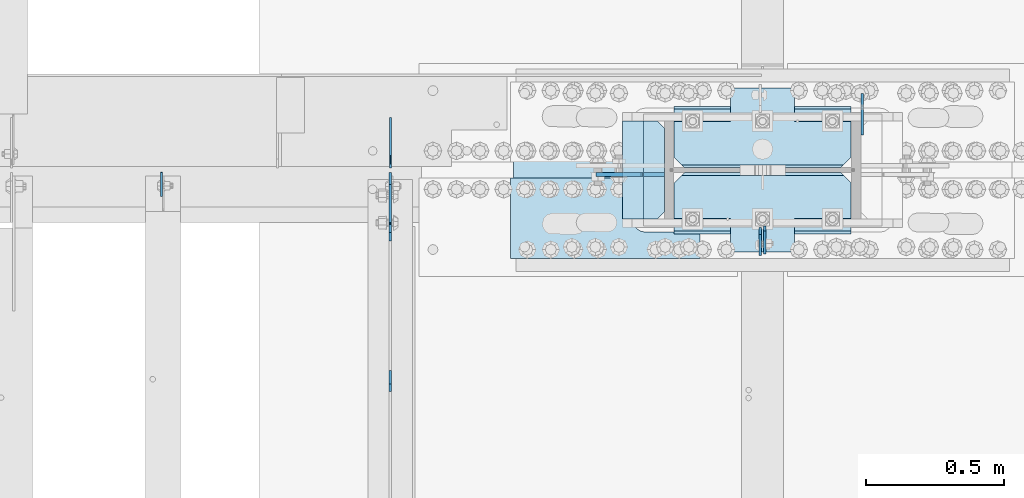
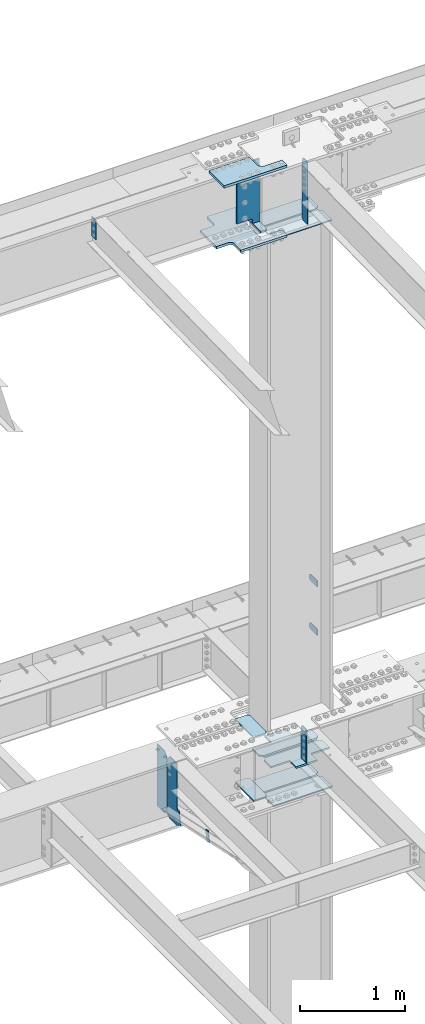
# One storey, part 1616 of 1763: 20 plates, 6 elements without a shape of their own.
"""IFC2X3 building model written with IfcOpenShell, lengths in millimetres."""

import ifcopenshell
import ifcopenshell.guid

model = None  # the IFC model being written
_history = None  # IfcOwnerHistory: only IFC2X3 demands one
_inside = {}  # id of a spatial element -> (the spatial element, [elements in it])
_under = {}  # id of a project, library or spatial element -> (it, [spatial elements below it])
_declared = {}  # id of a project -> (the project, [libraries it declares])
_typed = {}  # id of a type object -> (the type object, [elements of that type])
_made_of = {}  # id of a material, layer set ... -> (it, [elements and type objects made of it])


def new_model(schema):
    """Start an empty IFC model of exactly this schema.

    Asked for "IFC4X3", IfcOpenShell would pick the latest addendum, in which some entities
    have other attributes; the version numbers below select the first issue.
    IFC2X3 requires an IfcOwnerHistory on every rooted entity: one is made here for all.
    """
    global model, _history
    if schema == "IFC4X3":
        model = ifcopenshell.file(schema_version=(4, 3, 0, 0))
    else:
        model = ifcopenshell.file(schema=schema)
    _inside.clear()
    _under.clear()
    _declared.clear()
    _typed.clear()
    _made_of.clear()
    _history = None
    if model.schema == "IFC2X3":
        org = make("IfcOrganization", Name="unknown")
        user = make(
            "IfcPersonAndOrganization",
            ThePerson=make("IfcPerson", FamilyName="unknown"),
            TheOrganization=org,
        )
        app = make(
            "IfcApplication",
            ApplicationDeveloper=org,
            Version="unknown",
            ApplicationFullName="unknown",
            ApplicationIdentifier="unknown",
        )
        _history = make(
            "IfcOwnerHistory",
            OwningUser=user,
            OwningApplication=app,
            ChangeAction="ADDED",
            CreationDate=0,
        )
    return model


def make(cls, **values):
    """One entity of the class cls with the attributes given. An attribute that is None is left unset."""
    return model.create_entity(
        cls, **{name: value for name, value in values.items() if value is not None}
    )


def rooted(cls, **values):
    """An entity with a GlobalId (a new one), such as an element, a storey or a relation."""
    return make(cls, GlobalId=ifcopenshell.guid.new(), OwnerHistory=_history, **values)


def si_unit(unit_type, name, prefix=None):
    """IfcSIUnit, for example si_unit("LENGTHUNIT", "METRE", prefix="MILLI")."""
    return make("IfcSIUnit", UnitType=unit_type, Prefix=prefix, Name=name)


def assignment(units):
    """IfcUnitAssignment: the units of a project."""
    return None if units is None else make("IfcUnitAssignment", Units=units)


def point(xyz):
    """IfcCartesianPoint."""
    return None if xyz is None else make("IfcCartesianPoint", Coordinates=xyz)


def direction(xyz):
    """IfcDirection."""
    return None if xyz is None else make("IfcDirection", DirectionRatios=xyz)


def frame(location, z_axis=None, x_axis=None):
    """IfcAxis2Placement3D, a coordinate frame: its origin and axes. An axis left out is left unset."""
    return make(
        "IfcAxis2Placement3D",
        Location=point(location),
        Axis=direction(z_axis),
        RefDirection=direction(x_axis),
    )


def origin_with_axes():
    """The frame at (0, 0, 0) with the z axis (0, 0, 1) and the x axis (1, 0, 0) written out."""
    return frame((0.0, 0.0, 0.0), z_axis=(0.0, 0.0, 1.0), x_axis=(1.0, 0.0, 0.0))


def place(relative_to, where):
    """IfcLocalPlacement: puts the frame where relative to a parent placement (None: the world)."""
    return make(
        "IfcLocalPlacement", PlacementRelTo=relative_to, RelativePlacement=where
    )


def context(
    kind, dimensions, precision=None, world=None, true_north=None, identifier=None
):
    """IfcGeometricRepresentationContext, for example the 3D "Model" context."""
    return make(
        "IfcGeometricRepresentationContext",
        ContextIdentifier=identifier,
        ContextType=kind,
        CoordinateSpaceDimension=dimensions,
        Precision=precision,
        WorldCoordinateSystem=world,
        TrueNorth=true_north,
    )


def subcontext(parent, identifier, kind, view, scale=None):
    """IfcGeometricRepresentationSubContext, for example "Body" below "Model"."""
    return make(
        "IfcGeometricRepresentationSubContext",
        ContextIdentifier=identifier,
        ContextType=kind,
        ParentContext=parent,
        TargetScale=scale,
        TargetView=view,
    )


def project(units=None, contexts=None):
    """IfcProject with its units and contexts."""
    return rooted(
        "IfcProject",
        Name="project",
        RepresentationContexts=contexts,
        UnitsInContext=assignment(units),
    )


def spatial(cls, under=None, at=None, **own):
    """A site, building, storey or space (cls), placed at a placement, below another one or the project."""
    s = rooted(cls, ObjectPlacement=at, **own)
    if under is not None:
        _under.setdefault(under.id(), (under, []))[1].append(s)
    return s


def faces_of(points, faces, orient=None, outer=None):
    """IfcFace entities. A face is a list of loops; a loop is a list of indices into points, from 0.

    orient and outer hold one flag for each loop. By default every Orientation is true, the
    first loop of a face is its IfcFaceOuterBound and the others are IfcFaceBound.
    """
    made = []
    for i, loops in enumerate(faces):
        bounds = []
        for j, loop in enumerate(loops):
            is_outer = j == 0 if outer is None else outer[i][j]
            bounds.append(
                make(
                    "IfcFaceOuterBound" if is_outer else "IfcFaceBound",
                    Bound=make("IfcPolyLoop", Polygon=[points[k] for k in loop]),
                    Orientation=True if orient is None else orient[i][j],
                )
            )
        made.append(make("IfcFace", Bounds=bounds))
    return made


def faceted_brep(points, faces, orient=None, outer=None, voids=None):
    """IfcFacetedBrep: a solid bounded by flat faces; with voids (closed shells), ...WithVoids."""
    shared = [point(p) for p in points]
    hull = make("IfcClosedShell", CfsFaces=faces_of(shared, faces, orient, outer))
    if voids is None:
        return make("IfcFacetedBrep", Outer=hull)
    return make(
        "IfcFacetedBrepWithVoids",
        Outer=hull,
        Voids=[
            make(cls, CfsFaces=faces_of(shared, fs, o, b)) for cls, fs, o, b in voids
        ],
    )


def shape(context_of_items, identifier, shape_type, items):
    """IfcShapeRepresentation: the items that make up one representation, for example the "Body"."""
    return make(
        "IfcShapeRepresentation",
        ContextOfItems=context_of_items,
        RepresentationIdentifier=identifier,
        RepresentationType=shape_type,
        Items=items,
    )


def material(Name=None, Category=None):
    """IfcMaterial."""
    return make("IfcMaterial", Name=Name, Category=Category)


def made_of(thing, what):
    """Note that an element or type object is made of a material, layer set ...; save() writes the relation."""
    if what is not None:
        _made_of.setdefault(what.id(), (what, []))[1].append(thing)
    return thing


def type_object(cls, material=None, **own):
    """A type object (cls), such as IfcWallType, which elements share."""
    return made_of(rooted(cls, **own), material)


def element(
    cls,
    number,
    at=None,
    inside=None,
    cuts=None,
    type_object=None,
    material=None,
    context=None,
    identifier="Body",
    shape_type=None,
    held_by="IfcProductDefinitionShape",
    body=None,
    shapes=None,
    **own,
):
    """One element of the class cls, such as IfcWall. Its Tag is "e" and its number.

    at: its placement. inside: the storey or other place that contains it. cuts: it is an
    opening in that element (IfcRelVoidsElement). A single representation is given by context,
    identifier, shape_type and body (its items); several are given by shapes. held_by: the class
    of the entity that holds the representations. save() writes the other relations.
    """
    e = rooted(cls, Tag="e%d" % number, ObjectPlacement=at, **own)
    if body is not None:
        shapes = [shape(context, identifier, shape_type, body)]
    if shapes is not None:
        e.Representation = make(held_by, Representations=shapes)
    if inside is not None:
        _inside.setdefault(inside.id(), (inside, []))[1].append(e)
    if cuts is not None:
        rooted(
            "IfcRelVoidsElement", RelatingBuildingElement=cuts, RelatedOpeningElement=e
        )
    if type_object is not None:
        _typed.setdefault(type_object.id(), (type_object, []))[1].append(e)
    return made_of(e, material)


def aggregate(whole, parts):
    """IfcRelAggregates: a whole, such as a stair, and the parts it consists of."""
    return rooted("IfcRelAggregates", RelatingObject=whole, RelatedObjects=parts)


def save(model, path):
    """Write the relations noted so far, then the file.

    IfcRelAggregates (storeys below a building ...), IfcRelContainedInSpatialStructure (elements
    in a storey), IfcRelDefinesByType, IfcRelAssociatesMaterial and IfcRelDeclares: one each for
    every whole, place, type object, material and project.
    """
    for whole, parts in _under.values():
        aggregate(whole, parts)
    for where, things in _inside.values():
        rooted(
            "IfcRelContainedInSpatialStructure",
            RelatedElements=things,
            RelatingStructure=where,
        )
    for kind, things in _typed.values():
        rooted("IfcRelDefinesByType", RelatedObjects=things, RelatingType=kind)
    for what, things in _made_of.values():
        rooted("IfcRelAssociatesMaterial", RelatedObjects=things, RelatingMaterial=what)
    for by, libraries in _declared.values():
        rooted("IfcRelDeclares", RelatingContext=by, RelatedDefinitions=libraries)
    model.write(path)


model = new_model("IFC2X3")

# Units and contexts
model_context = context("Model", 3, precision=1e-05, world=origin_with_axes())
body_context = subcontext(model_context, "Body", "Model", "MODEL_VIEW")
ifc_project = project(units=[si_unit("LENGTHUNIT", "METRE", prefix="MILLI"), si_unit("AREAUNIT", "SQUARE_METRE"), si_unit("VOLUMEUNIT", "CUBIC_METRE"), si_unit("MASSUNIT", "GRAM", prefix="KILO"), si_unit("TIMEUNIT", "SECOND"), si_unit("PLANEANGLEUNIT", "RADIAN"), si_unit("SOLIDANGLEUNIT", "STERADIAN"), si_unit("THERMODYNAMICTEMPERATUREUNIT", "DEGREE_CELSIUS"), si_unit("LUMINOUSINTENSITYUNIT", "LUMEN")], contexts=[model_context])

# Site, building, storey
site_placement = place(None, origin_with_axes())
site = spatial("IfcSite", under=ifc_project, at=site_placement, CompositionType="ELEMENT")
building_placement = place(site_placement, origin_with_axes())
building = spatial("IfcBuilding", under=site, at=building_placement, Name="Undefined", CompositionType="ELEMENT")
storey_placement = place(building_placement, origin_with_axes())
storey = spatial("IfcBuildingStorey", under=building, at=storey_placement, Name="Undefined", CompositionType="ELEMENT", Elevation=0.0)

# Assembly, plates
assembly_1_placement = place(storey_placement, origin_with_axes())
assembly_1 = element("IfcElementAssembly", 1, at=assembly_1_placement, inside=storey, Name="COLUMN", AssemblyPlace="NOTDEFINED", PredefinedType="RIGID_FRAME")
ifc_material_1 = material(Name="STEEL/A36")
plate_type_1 = type_object("IfcPlateType", PredefinedType="NOTDEFINED")
plate_1_placement = place(assembly_1_placement, frame((-61232.4872736984, 52247.8, 6489.69999847412), z_axis=(0.0, 0.0, -1.0), x_axis=(0.0, 1.0, 0.0)))
plate_1 = element("IfcPlate", 2, at=plate_1_placement, type_object=plate_type_1, material=ifc_material_1, Name="PLATE", context=body_context, shape_type="Brep", body=[
    faceted_brep([(0.0, -4.76249999999982, 0.0), (0.0, -4.76250000000073, 76.1999969482422), (0.0, 4.76250000000073, 76.1999969482422), (0.0, 4.76249999999982, 0.0), (114.299995422363, -4.76250000000073, 76.1999969482422), (114.299995422363, 4.76250000000073, 76.1999969482422), (126.073542436527, -4.76250000000073, 74.3352502937696), (126.073542436527, 4.76250000000073, 74.3352502937696), (136.694612637817, -4.76250000000073, 68.923544725345), (136.694612637817, 4.76250000000073, 68.923544725345), (145.123541673587, -4.76250000000073, 60.4946156895749), (145.123541673587, 4.76250000000073, 60.4946156895749), (150.535247242013, -4.76250000000073, 49.8735454882844), (150.535247242013, 4.76250000000073, 49.8735454882844), (152.399993896484, -4.76250000000073, 38.0999984741211), (152.399993896484, 4.76250000000073, 38.0999984741211), (150.535247242013, -4.76250000000073, 26.3264514599578), (150.535247242013, 4.76250000000073, 26.3264514599578), (145.123541673587, -4.76250000000073, 15.7053812586673), (145.123541673587, 4.76250000000073, 15.7053812586673), (136.694612637817, -4.76250000000073, 7.27645222289721), (136.694612637817, 4.76250000000073, 7.27645222289721), (126.073542436527, -4.76250000000073, 1.86474665447258), (126.073542436527, 4.76250000000073, 1.86474665447258), (114.299995422363, -4.76250000000073, 0.0), (114.299995422363, 4.76250000000073, 0.0)], [[[0, 1, 2, 3]], [[1, 4, 5, 2]], [[4, 6, 7, 5]], [[6, 8, 9, 7]], [[8, 10, 11, 9]], [[10, 12, 13, 11]], [[12, 14, 15, 13]], [[14, 16, 17, 15]], [[16, 18, 19, 17]], [[18, 20, 21, 19]], [[20, 22, 23, 21]], [[22, 24, 25, 23]], [[24, 0, 3, 25]], [[5, 7, 9, 11, 13, 15, 17, 19, 21, 23, 25, 3, 2]], [[24, 22, 20, 18, 16, 14, 12, 10, 8, 6, 4, 1, 0]]]),
])
plate_2_placement = place(assembly_1_placement, frame((-61232.4872736984, 52247.8, 5930.89999847412), z_axis=(0.0, 0.0, -1.0), x_axis=(0.0, 1.0, 0.0)))
plate_2 = element("IfcPlate", 3, at=plate_2_placement, type_object=plate_type_1, material=ifc_material_1, Name="PLATE", context=body_context, shape_type="Brep", body=[
    faceted_brep([(0.0, -4.76249999999982, 0.0), (0.0, -4.76250000000073, 76.1999969482422), (0.0, 4.76250000000073, 76.1999969482422), (0.0, 4.76249999999982, 0.0), (114.299995422363, -4.76250000000073, 76.1999969482422), (114.299995422363, 4.76250000000073, 76.1999969482422), (126.073542436527, -4.76250000000073, 74.3352502937696), (126.073542436527, 4.76250000000073, 74.3352502937696), (136.694612637817, -4.76250000000073, 68.923544725345), (136.694612637817, 4.76250000000073, 68.923544725345), (145.123541673587, -4.76250000000073, 60.4946156895749), (145.123541673587, 4.76250000000073, 60.4946156895749), (150.535247242013, -4.76250000000073, 49.8735454882844), (150.535247242013, 4.76250000000073, 49.8735454882844), (152.399993896484, -4.76250000000073, 38.0999984741211), (152.399993896484, 4.76250000000073, 38.0999984741211), (150.535247242013, -4.76250000000073, 26.3264514599578), (150.535247242013, 4.76250000000073, 26.3264514599578), (145.123541673587, -4.76250000000073, 15.7053812586673), (145.123541673587, 4.76250000000073, 15.7053812586673), (136.694612637817, -4.76250000000073, 7.27645222289721), (136.694612637817, 4.76250000000073, 7.27645222289721), (126.073542436527, -4.76250000000073, 1.86474665447258), (126.073542436527, 4.76250000000073, 1.86474665447258), (114.299995422363, -4.76250000000073, 0.0), (114.299995422363, 4.76250000000073, 0.0)], [[[0, 1, 2, 3]], [[1, 4, 5, 2]], [[4, 6, 7, 5]], [[6, 8, 9, 7]], [[8, 10, 11, 9]], [[10, 12, 13, 11]], [[12, 14, 15, 13]], [[14, 16, 17, 15]], [[16, 18, 19, 17]], [[18, 20, 21, 19]], [[20, 22, 23, 21]], [[22, 24, 25, 23]], [[24, 0, 3, 25]], [[5, 7, 9, 11, 13, 15, 17, 19, 21, 23, 25, 3, 2]], [[24, 22, 20, 18, 16, 14, 12, 10, 8, 6, 4, 1, 0]]]),
])

# Assembly, plate
assembly_2_placement = place(storey_placement, origin_with_axes())
assembly_2 = element("IfcElementAssembly", 4, at=assembly_2_placement, inside=storey, Name="ANGLE BRACE", AssemblyPlace="NOTDEFINED", PredefinedType="RIGID_FRAME")
plate_type_2 = type_object("IfcPlateType", PredefinedType="NOTDEFINED")
plate_3_placement = place(assembly_2_placement, frame((-62948.5747736983, 51342.4281032895, 4746.91590772782), z_axis=(0.0, -0.208168683014592, -0.978092940068566), x_axis=(0.0, 0.978092940068566, -0.208168683014588)))
plate_3 = element("IfcPlate", 5, at=plate_3_placement, type_object=plate_type_2, material=ifc_material_1, Name="PLATE", context=body_context, shape_type="Brep", body=[
    faceted_brep([(0.0, -4.76249999999982, 0.0), (2.11002770811319e-09, -4.76249999999709, 127.040328979458), (2.11002770811319e-09, 4.76249999999709, 127.040328979458), (0.0, 4.76249999999982, 0.0), (50.7119293213109, -4.76249999999709, 126.999992370584), (50.7119293213109, 4.76249999999709, 126.999992370584), (50.7119293211581, -4.76249999999709, 1.63709046319127e-11), (50.7119293211581, 4.76249999999709, 1.63709046319127e-11)], [[[0, 1, 2, 3]], [[1, 4, 5, 2]], [[4, 6, 7, 5]], [[6, 0, 3, 7]], [[5, 7, 3, 2]], [[6, 4, 1, 0]]]),
])
aggregate(assembly_2, [plate_3])

# Plate
plate_type_3 = type_object("IfcPlateType", PredefinedType="NOTDEFINED")
plate_4_placement = place(assembly_1_placement, frame((-61586.5002737632, 51917.5999999994, 11718.1532534164), z_axis=(0.0, -1.0, 0.0), x_axis=(0.0, 0.0, -1.0)))
plate_4 = element("IfcPlate", 6, at=plate_4_placement, type_object=plate_type_3, material=ifc_material_1, Name="PLATE", context=body_context, shape_type="Brep", body=[
    faceted_brep([(0.0, -3.96899999999732, 19.0499992370605), (-1.18234311230481e-11, -3.96900000000096, 101.599998474121), (-1.18234311230481e-11, 3.96900000000096, 101.599998474121), (0.0, 3.96899999999732, 19.0499992370605), (719.137512207031, -3.96899999999732, 101.599998474121), (719.137512207031, 3.96899999999732, 101.599998474121), (719.137512207031, -3.96899999999732, 19.0499992370605), (719.137512207031, 3.96899999999732, 19.0499992370605), (700.087512969971, -3.96899999999732, 0.0), (700.087512969971, 3.96899999999732, 0.0), (19.0499992370605, -3.96899999999732, 0.0), (19.0499992370605, 3.96899999999732, 0.0)], [[[0, 1, 2, 3]], [[1, 4, 5, 2]], [[4, 6, 7, 5]], [[6, 8, 9, 7]], [[8, 10, 11, 9]], [[10, 0, 3, 11]], [[5, 7, 9, 11, 3, 2]], [[10, 8, 6, 4, 1, 0]]]),
])

ifc_material_2 = material(Name="STEEL/A572-GR.50")
plate_type_4 = type_object("IfcPlateType", PredefinedType="NOTDEFINED")
plate_5_placement = place(assembly_1_placement, frame((-61603.1685236983, 51911.25, 5165.725), z_axis=(0.0, -1.0, 0.0), x_axis=(0.0, 0.0, -1.0)))
plate_5 = element("IfcPlate", 7, at=plate_5_placement, type_object=plate_type_4, material=ifc_material_2, Name="PLATE", context=body_context, shape_type="Brep", body=[
    faceted_brep([(25.3999996185303, -4.76250000000073, 0.0), (0.0, -4.76250000000073, 25.3999996185303), (0.0, 4.76250000000073, 25.3999996185303), (25.3999996185303, 4.76250000000073, 0.0), (1.45519152283669e-11, -4.76250000000448, 101.60001373291), (390.524993896484, -4.76249999999709, 101.599998474121), (390.524993896484, 4.76249999999709, 101.599998474121), (0.0, 4.76250000000243, 101.60001373291), (390.524993896484, -4.76249999999709, 0.0), (390.524993896484, 4.76249999999709, 0.0)], [[[0, 1, 2, 3]], [[4, 5, 6, 7]], [[5, 8, 9, 6]], [[9, 8, 0, 3]], [[7, 6, 9, 3, 2]], [[4, 7, 2, 1]], [[8, 5, 4, 1, 0]]]),
])

# Assembly, plate
assembly_3_placement = place(storey_placement, origin_with_axes())
assembly_3 = element("IfcElementAssembly", 8, at=assembly_3_placement, inside=storey, Name="BEAM", AssemblyPlace="NOTDEFINED", PredefinedType="RIGID_FRAME")
plate_type_5 = type_object("IfcPlateType", PredefinedType="NOTDEFINED")
plate_6_placement = place(assembly_3_placement, frame((-62946.987273746, 52128.7375, 4448.175), z_axis=(0.0, 0.0, 1.0), x_axis=(0.0, 1.0, 0.0)))
plate_6 = element("IfcPlate", 9, at=plate_6_placement, type_object=plate_type_5, material=ifc_material_1, Name="PLATE", context=body_context, shape_type="Brep", body=[
    faceted_brep([(0.0, -3.17500000000291, 44.4500000000007), (0.0, -3.17500000000291, 673.099987030029), (0.0, 3.17500000000291, 673.099987030029), (0.0, 3.17500000000291, 44.4500000000007), (44.4500007629395, -3.17500000000291, 717.549987792969), (44.4500007629395, 3.17500000000291, 717.549987792969), (182.5625, -3.17500000000291, 717.549987792969), (182.5625, 3.17500000000291, 717.549987792969), (182.5625, -3.17500000000291, 0.0), (182.5625, 3.17500000000291, 0.0), (44.4500007629395, -3.17500000000291, 0.0), (44.4500007629395, 3.17500000000291, 0.0)], [[[0, 1, 2, 3]], [[1, 4, 5, 2]], [[4, 6, 7, 5]], [[6, 8, 9, 7]], [[8, 10, 11, 9]], [[10, 0, 3, 11]], [[5, 7, 9, 11, 3, 2]], [[10, 8, 6, 4, 1, 0]]]),
])

# Plate
ifc_material_3 = material(Name="STEEL/A572-50")
plate_type_6 = type_object("IfcPlateType", PredefinedType="NOTDEFINED")
plate_7_placement = place(assembly_1_placement, frame((-62104.0247736984, 52298.6, 4427.5375), z_axis=(1.0, 0.0, 0.0), x_axis=(0.0, -1.0, 0.0)))
plate_7 = element("IfcPlate", 10, at=plate_7_placement, type_object=plate_type_6, material=ifc_material_3, Name="PLATE", context=body_context, shape_type="Brep", body=[
    faceted_brep([(-7.27595761418343e-12, -7.9375, 0.0), (0.0, -7.9375, 126.999994277954), (0.0, 7.9375, 126.999994277954), (-7.27595761418343e-12, 7.9375, 0.0), (25.3999996185303, -7.9375, 152.399993896484), (25.3999996185303, 7.9375, 152.399993896484), (330.200006484985, -7.9375, 152.399993896484), (330.200006484985, 7.9375, 152.399993896484), (355.600006103516, -7.9375, 126.999994277954), (355.600006103516, 7.9375, 126.999994277954), (355.600006103516, -7.9375, 0.0), (355.600006103516, 7.9375, 0.0)], [[[0, 1, 2, 3]], [[1, 4, 5, 2]], [[4, 6, 7, 5]], [[6, 8, 9, 7]], [[8, 10, 11, 9]], [[10, 0, 3, 11]], [[5, 7, 9, 11, 3, 2]], [[10, 8, 6, 4, 1, 0]]]),
])

plate_8_placement = place(assembly_1_placement, frame((-62104.0247736984, 52298.6, 5157.7875), z_axis=(1.0, 0.0, 0.0), x_axis=(0.0, -1.0, 0.0)))
plate_8 = element("IfcPlate", 11, at=plate_8_placement, type_object=plate_type_6, material=ifc_material_3, Name="PLATE", context=body_context, shape_type="Brep", body=[
    faceted_brep([(-7.27595761418343e-12, -7.9375, 0.0), (0.0, -7.9375, 126.999994277954), (0.0, 7.9375, 126.999994277954), (-7.27595761418343e-12, 7.9375, 0.0), (25.3999996185303, -7.9375, 152.399993896484), (25.3999996185303, 7.9375, 152.399993896484), (330.200006484985, -7.9375, 152.399993896484), (330.200006484985, 7.9375, 152.399993896484), (355.600006103516, -7.9375, 126.999994277954), (355.600006103516, 7.9375, 126.999994277954), (355.600006103516, -7.9375, 0.0), (355.600006103516, 7.9375, 0.0)], [[[0, 1, 2, 3]], [[1, 4, 5, 2]], [[4, 6, 7, 5]], [[6, 8, 9, 7]], [[8, 10, 11, 9]], [[10, 0, 3, 11]], [[5, 7, 9, 11, 3, 2]], [[10, 8, 6, 4, 1, 0]]]),
])

plate_type_7 = type_object("IfcPlateType", PredefinedType="NOTDEFINED")
plate_9_placement = place(assembly_1_placement, frame((-61916.6997736983, 51889.025, 4335.4625), z_axis=(1.0, 0.0, 0.0), x_axis=(0.0, 1.0, 0.0)))
plate_9 = element("IfcPlate", 12, at=plate_9_placement, type_object=plate_type_7, material=ifc_material_3, Name="HORIZONTAL SHEAR PLAT", context=body_context, shape_type="Brep", body=[
    faceted_brep([(-7.27595761418343e-12, -7.9375, 0.0), (0.0, -7.9375, 644.524963378906), (0.0, 7.9375, 644.524963378906), (-7.27595761418343e-12, 7.9375, 0.0), (184.150001525879, -7.9375, 644.524963378906), (184.150001525879, 7.9375, 644.524963378906), (222.25, -7.9375, 606.424964904785), (222.25, 7.9375, 606.424964904785), (222.25, -7.9375, 38.0999984741211), (222.25, 7.9375, 38.0999984741211), (184.150001525879, -7.9375, 0.0), (184.150001525879, 7.9375, 0.0)], [[[0, 1, 2, 3]], [[1, 4, 5, 2]], [[4, 6, 7, 5]], [[6, 8, 9, 7]], [[8, 10, 11, 9]], [[10, 0, 3, 11]], [[5, 7, 9, 11, 3, 2]], [[10, 8, 6, 4, 1, 0]]]),
])

plate_10_placement = place(assembly_1_placement, frame((-61916.6997736983, 52352.575, 4335.4625), z_axis=(1.0, 0.0, 0.0), x_axis=(0.0, -1.0, 0.0)))
plate_10 = element("IfcPlate", 13, at=plate_10_placement, type_object=plate_type_7, material=ifc_material_3, Name="HORIZONTAL SHEAR PLAT", context=body_context, shape_type="Brep", body=[
    faceted_brep([(-7.27595761418343e-12, -7.9375, 0.0), (0.0, -7.9375, 644.524963378906), (0.0, 7.9375, 644.524963378906), (-7.27595761418343e-12, 7.9375, 0.0), (184.150001525879, -7.9375, 644.524963378906), (184.150001525879, 7.9375, 644.524963378906), (222.25, -7.9375, 606.424964904785), (222.25, 7.9375, 606.424964904785), (222.25, -7.9375, 38.0999984741211), (222.25, 7.9375, 38.0999984741211), (184.150001525879, -7.9375, 0.0), (184.150001525879, 7.9375, 0.0)], [[[0, 1, 2, 3]], [[1, 4, 5, 2]], [[4, 6, 7, 5]], [[6, 8, 9, 7]], [[8, 10, 11, 9]], [[10, 0, 3, 11]], [[5, 7, 9, 11, 3, 2]], [[10, 8, 6, 4, 1, 0]]]),
])

plate_type_8 = type_object("IfcPlateType", PredefinedType="NOTDEFINED")
plate_11_placement = place(assembly_1_placement, frame((-61272.1747736983, 51898.55, 10887.0749917654), z_axis=(-1.0, 0.0, 0.0), x_axis=(0.0, 1.0, 0.0)))
plate_11 = element("IfcPlate", 14, at=plate_11_placement, type_object=plate_type_8, material=ifc_material_3, Name="PLATE", context=body_context, shape_type="Brep", body=[
    faceted_brep([(0.0, -6.34999999999491, 1.45519152283669e-11), (0.0, -6.35000000000036, 644.525024414062), (0.0, 6.35000000000036, 644.525024414062), (0.0, 6.34999999999491, -2.91038304567337e-11), (174.625007629395, -6.35000000000036, 644.525024414062), (174.625007629395, 6.35000000000036, 644.525024414062), (212.725006103516, -6.35000000000036, 606.425025939941), (212.725006103516, 6.35000000000036, 606.425025939941), (212.725006103516, -6.35000000000036, 38.0999984741211), (212.725006103516, 6.35000000000036, 38.0999984741211), (174.625007629395, -6.35000000000036, 0.0), (174.625007629395, 6.35000000000036, 0.0)], [[[0, 1, 2, 3]], [[1, 4, 5, 2]], [[4, 6, 7, 5]], [[6, 8, 9, 7]], [[8, 10, 11, 9]], [[10, 0, 3, 11]], [[5, 7, 9, 11, 3, 2]], [[10, 8, 6, 4, 1, 0]]]),
])

plate_12_placement = place(assembly_1_placement, frame((-61272.1747736983, 52130.325, 10887.0749917654), z_axis=(-1.0, 0.0, 0.0), x_axis=(0.0, 1.0, 0.0)))
plate_12 = element("IfcPlate", 15, at=plate_12_placement, type_object=plate_type_8, material=ifc_material_3, Name="PLATE", context=body_context, shape_type="Brep", body=[
    faceted_brep([(0.0, -6.34999999999854, 38.0999984741211), (0.0, -6.35000000000036, 606.425025939941), (0.0, 6.35000000000036, 606.425025939941), (0.0, 6.34999999999854, 38.0999984741211), (38.0999984741211, -6.35000000000036, 644.525024414062), (38.0999984741211, 6.35000000000036, 644.525024414062), (212.725006103516, -6.35000000000036, 644.525024414062), (212.725006103516, 6.35000000000036, 644.525024414062), (212.725006103516, -6.35000000000036, 0.0), (212.725006103516, 6.35000000000036, 0.0), (38.0999984741211, -6.34999999999854, 0.0), (38.0999984741211, 6.34999999999854, 0.0)], [[[0, 1, 2, 3]], [[1, 4, 5, 2]], [[4, 6, 7, 5]], [[6, 8, 9, 7]], [[8, 10, 11, 9]], [[10, 0, 3, 11]], [[5, 7, 9, 11, 3, 2]], [[10, 8, 6, 4, 1, 0]]]),
])

plate_type_9 = type_object("IfcPlateType", PredefinedType="NOTDEFINED")
plate_13_placement = place(assembly_1_placement, frame((-61272.1747736983, 51822.35, 4749.8), z_axis=(-1.0, 0.0, 0.0), x_axis=(0.0, 1.0, 0.0)))
plate_13 = element("IfcPlate", 16, at=plate_13_placement, type_object=plate_type_9, material=ifc_material_3, Name="PLATE", context=body_context, shape_type="Brep", body=[
    faceted_brep([(288.924987792969, -7.65116965339985e-07, 606.425025939941), (279.399988558085, -9.52499999999964, 615.950025174825), (279.399988558085, -9.52499999999964, 28.5749992392375), (288.924987792969, -7.65116965339985e-07, 38.0999984741211), (250.824989318848, -9.52499999999964, 644.525024414062), (250.824989318848, 9.52499999999964, 644.525024414062), (122.237487792991, 9.52499999999964, 644.525024414062), (122.237487792991, -9.52499999999964, 644.525015258769), (122.237487792983, 9.52499999999964, 438.14999999998), (122.237487792983, -9.52499999999964, 438.14999999998), (0.0, 9.52499999999964, 438.149991923026), (0.0, -9.52499999999964, 438.149991923026), (0.0, 9.52499999999964, 206.375007181632), (0.0, -9.52499999999964, 206.375007181632), (250.824989318848, 9.52499999999964, 0.0), (250.824989318848, -9.52499999999964, 0.0), (122.237487792998, -9.52499999999964, 0.0), (122.237487792998, 9.52499999999964, 0.0), (122.237487793005, -9.52499999999964, 206.375015258775), (122.237487793005, 9.52499999999964, 206.375015258775), (288.924987792969, 9.52499999999964, 606.425025939941), (288.924987792969, 9.52499999999964, 38.0999984741211)], [[[0, 1, 2, 3]], [[4, 5, 6, 7]], [[7, 6, 8, 9]], [[9, 8, 10, 11]], [[11, 10, 12, 13]], [[14, 15, 16, 17]], [[18, 19, 17, 16]], [[13, 12, 19, 18]], [[10, 8, 6, 5, 20, 21, 14, 17, 19, 12]], [[21, 20, 0, 3]], [[15, 14, 21, 3, 2]], [[4, 7, 9, 11, 13, 18, 16, 15, 2, 1]], [[20, 5, 4, 1, 0]]]),
])

plate_14_placement = place(assembly_1_placement, frame((-61272.1747736983, 52130.325, 4749.8), z_axis=(-1.0, 0.0, 0.0), x_axis=(0.0, 1.0, 0.0)))
plate_14 = element("IfcPlate", 17, at=plate_14_placement, type_object=plate_type_9, material=ifc_material_3, Name="PLATE", context=body_context, shape_type="Brep", body=[
    faceted_brep([(9.52499923488358, -9.52499999999964, 615.950025174825), (0.0, -7.65116965339985e-07, 606.425025939941), (0.0, 0.0, 38.0999984741211), (9.52499923488358, -9.52499999999964, 28.5749992392375), (288.924987792961, -9.52499999999964, 438.14999999998), (288.924987792969, 9.52499999999964, 438.14999999998), (166.687499999833, 9.52499999999964, 438.149991923055), (166.687499999833, -9.52499999999964, 438.149991923055), (288.924987792983, -9.52499999999964, 206.375015258775), (288.924987792969, 9.52499999999964, 206.375015258775), (38.0999984741211, -9.52500000000146, 0.0), (38.0999984741211, 9.52500000000146, 0.0), (166.6875, 9.52499999999964, 0.0), (166.6875, -9.52499999999964, 0.0), (166.687503076391, 9.52499999999964, 206.375007181618), (166.687503076391, -9.52499999999964, 206.375007181618), (0.0, 9.52500000000146, 38.0999984741211), (0.0, 9.52499999999964, 606.425025939941), (38.0999984741211, 9.52499999999964, 644.525024414062), (166.687503076224, 9.52499999999964, 644.525024414062), (166.687503076224, -9.52499999999964, 644.525024414062), (38.0999984741211, -9.52499999999964, 644.525024414062)], [[[0, 1, 2, 3]], [[4, 5, 6, 7]], [[5, 4, 8, 9]], [[10, 11, 12, 13]], [[13, 12, 14, 15]], [[8, 15, 14, 9]], [[12, 11, 16, 17, 18, 19, 6, 5, 9, 14]], [[20, 7, 6, 19]], [[18, 21, 20, 19]], [[10, 13, 15, 8, 4, 7, 20, 21, 0, 3]], [[16, 11, 10, 3, 2]], [[17, 16, 2, 1]], [[21, 18, 17, 1, 0]]]),
])

# Assembly, plate
assembly_4_placement = place(storey_placement, origin_with_axes())
assembly_4 = element("IfcElementAssembly", 18, at=assembly_4_placement, inside=storey, Name="PLATE", AssemblyPlace="NOTDEFINED", PredefinedType="RIGID_FRAME")
plate_type_10 = type_object("IfcPlateType", PredefinedType="NOTDEFINED")
plate_15_placement = place(assembly_4_placement, frame((-61821.4497736984, 52441.4750002128, 10955.3374917654), z_axis=(0.0, -1.0, 0.0), x_axis=(-1.0, 0.0, 0.0)))
plate_15 = element("IfcPlate", 19, at=plate_15_placement, type_object=plate_type_10, material=ifc_material_3, Name="PLATE", context=body_context, shape_type="Brep", body=[
    faceted_brep([(0.0, -14.2875000000058, 0.0), (0.0, -14.2875000000004, 95.25), (0.0, 14.2875000000004, 95.25), (0.0, 14.2875000000058, 0.0), (209.550006866455, -14.2875000000004, 95.25), (209.550006866455, 14.2875000000004, 95.25), (220.342425159237, -14.2875000000004, 96.9593511310522), (220.342425159237, 14.2875000000004, 96.9593511310522), (230.078406354325, -14.2875000000004, 101.920081325748), (230.078406354325, 14.2875000000004, 101.920081325748), (237.804924777767, -14.2875000000004, 109.646599749191), (237.804924777767, 14.2875000000004, 109.646599749191), (242.765654972463, -14.2875000000004, 119.382580944279), (242.765654972463, 14.2875000000004, 119.382580944279), (244.475006103516, -14.2875000000004, 130.174999237061), (244.475006103516, 14.2875000000004, 130.174999237061), (244.475006103516, -14.2875000000004, 511.174976348877), (244.475006103516, 14.2875000000004, 511.174976348877), (242.765654972463, -14.2875000000004, 521.967394641659), (242.765654972463, 14.2875000000004, 521.967394641659), (237.804924777767, -14.2875000000004, 531.703375836747), (237.804924777767, 14.2875000000004, 531.703375836747), (230.078406354325, -14.2875000000004, 539.429894260189), (230.078406354325, 14.2875000000004, 539.429894260189), (220.342425159237, -14.2875000000004, 544.390624454885), (220.342425159237, 14.2875000000004, 544.390624454885), (209.550006866455, -14.2875000000004, 546.099975585938), (209.550006866455, 14.2875000000004, 546.099975585938), (0.0, -14.2875000000004, 546.099975585938), (0.0, 14.2875000000004, 546.099975585938), (0.0, -14.2875000000004, 641.349975585938), (0.0, 14.2875000000004, 641.349975585938), (508.0, -14.2875000000004, 641.349975585938), (508.0, 14.2875000000004, 641.349975585938), (508.0, -14.2875000000004, 511.174999237061), (508.0, 14.2875000000004, 511.174999237061), (509.709351131052, -14.2875000000004, 500.382580944279), (509.709351131052, 14.2875000000004, 500.382580944279), (514.670081325748, -14.2875000000004, 490.646599749191), (514.670081325748, 14.2875000000004, 490.646599749191), (522.396599749191, -14.2875000000004, 482.920081325748), (522.396599749191, 14.2875000000004, 482.920081325748), (532.132580944279, -14.2875000000004, 477.959351131052), (532.132580944279, 14.2875000000004, 477.959351131052), (542.924999237061, -14.2875000000004, 476.25), (542.924999237061, 14.2875000000004, 476.25), (679.450012207031, -14.2875000000004, 476.25), (679.450012207031, 14.2875000000004, 476.25), (679.450012207031, -14.2875000000004, 165.100006103516), (679.450012207031, 14.2875000000004, 165.100006103516), (542.924999237061, -14.2875000000004, 165.100006103516), (542.924999237061, 14.2875000000004, 165.100006103516), (532.132580944279, -14.2875000000004, 163.390654972463), (532.132580944279, 14.2875000000004, 163.390654972463), (522.396599749191, -14.2875000000004, 158.429924777767), (522.396599749191, 14.2875000000004, 158.429924777767), (514.670081325748, -14.2875000000004, 150.703406354325), (514.670081325748, 14.2875000000004, 150.703406354325), (509.709351131052, -14.2875000000004, 140.967425159237), (509.709351131052, 14.2875000000004, 140.967425159237), (508.0, -14.2875000000004, 130.175006866455), (508.0, 14.2875000000004, 130.175006866455), (508.0, -14.2875000000004, 0.0), (508.0, 14.2875000000004, 0.0)], [[[0, 1, 2, 3]], [[1, 4, 5, 2]], [[4, 6, 7, 5]], [[6, 8, 9, 7]], [[8, 10, 11, 9]], [[10, 12, 13, 11]], [[12, 14, 15, 13]], [[14, 16, 17, 15]], [[16, 18, 19, 17]], [[18, 20, 21, 19]], [[20, 22, 23, 21]], [[22, 24, 25, 23]], [[24, 26, 27, 25]], [[26, 28, 29, 27]], [[28, 30, 31, 29]], [[30, 32, 33, 31]], [[32, 34, 35, 33]], [[34, 36, 37, 35]], [[36, 38, 39, 37]], [[38, 40, 41, 39]], [[40, 42, 43, 41]], [[42, 44, 45, 43]], [[44, 46, 47, 45]], [[46, 48, 49, 47]], [[48, 50, 51, 49]], [[50, 52, 53, 51]], [[52, 54, 55, 53]], [[54, 56, 57, 55]], [[56, 58, 59, 57]], [[58, 60, 61, 59]], [[60, 62, 63, 61]], [[62, 0, 3, 63]], [[5, 7, 9, 11, 13, 15, 17, 19, 21, 23, 25, 27, 29, 31, 33, 35, 37, 39, 41, 43, 45, 47, 49, 51, 53, 55, 57, 59, 61, 63, 3, 2]], [[62, 60, 58, 56, 54, 52, 50, 48, 46, 44, 42, 40, 38, 36, 34, 32, 30, 28, 26, 24, 22, 20, 18, 16, 14, 12, 10, 8, 6, 4, 1, 0]]]),
])
aggregate(assembly_4, [plate_15])

assembly_5_placement = place(storey_placement, origin_with_axes())
assembly_5 = element("IfcElementAssembly", 20, at=assembly_5_placement, inside=storey, Name="TOP PLATE", AssemblyPlace="NOTDEFINED", PredefinedType="RIGID_FRAME")
plate_type_11 = type_object("IfcPlateType", PredefinedType="NOTDEFINED")
plate_16_placement = place(assembly_5_placement, frame((-62065.9247736984, 52092.2250002128, 11761.7874917654), z_axis=(0.0, -1.0, 0.0), x_axis=(-1.0, 0.0, 0.0)))
plate_16 = element("IfcPlate", 21, at=plate_16_placement, type_object=plate_type_11, material=ifc_material_3, Name="TOP PLATE", context=body_context, shape_type="Brep", body=[
    faceted_brep([(0.0, -14.2875000000058, 0.0), (0.0, -14.2875000000004, 152.400001525879), (0.0, 14.2875000000004, 152.400001525879), (0.0, 14.2875000000058, 0.0), (-3.38355483795021, -14.2875000000004, 169.410284201171), (-3.38355483795021, 14.2875000000004, 169.410284201171), (-13.0191037997211, -14.2875000000004, 183.830902303795), (-13.0191037997211, 14.2875000000004, 183.830902303795), (-27.4397219023449, -14.2875000000004, 193.466451265565), (-27.4397219023449, 14.2875000000004, 193.466451265565), (-44.4500007629395, -14.2875000000004, 196.850006103516), (-44.4500007629395, 14.2875000000004, 196.850006103516), (-244.475006103516, -14.2875000000004, 196.850006103516), (-244.475006103516, 14.2875000000004, 196.850006103516), (-244.475006103516, -14.2875000000004, 292.100006103516), (-244.475006103516, 14.2875000000004, 292.100006103516), (444.5, -14.2875000000004, 292.100006103516), (444.5, 14.2875000000004, 292.100006103516), (444.5, -14.2875000000004, 0.0), (444.5, 14.2875000000004, 0.0)], [[[0, 1, 2, 3]], [[1, 4, 5, 2]], [[4, 6, 7, 5]], [[6, 8, 9, 7]], [[8, 10, 11, 9]], [[10, 12, 13, 11]], [[12, 14, 15, 13]], [[14, 16, 17, 15]], [[16, 18, 19, 17]], [[18, 0, 3, 19]], [[5, 7, 9, 11, 13, 15, 17, 19, 3, 2]], [[18, 16, 14, 12, 10, 8, 6, 4, 1, 0]]]),
])
aggregate(assembly_5, [plate_16])

# Plate
plate_type_12 = type_object("IfcPlateType", PredefinedType="NOTDEFINED")
plate_17_placement = place(assembly_1_placement, frame((-61951.6247736983, 51943.0, 10980.7374917654), z_axis=(-1.0, 0.0, 0.0), x_axis=(0.0, 1.0, 0.0)))
plate_17 = element("IfcPlate", 22, at=plate_17_placement, type_object=plate_type_12, material=ifc_material_3, Name="BRIDGE PLATE", context=body_context, shape_type="Brep", body=[
    faceted_brep([(0.0, -11.1124999999993, 25.3999996185303), (0.0, -11.1124999999993, 76.1999969482422), (0.0, 11.1124999999993, 76.1999969482422), (0.0, 11.1124999999993, 25.3999996185303), (355.600006103516, -11.1124999999993, 76.1999969482422), (355.600006103516, 11.1124999999993, 76.1999969482422), (355.600006103516, -11.1124999999993, 25.3999996185303), (355.600006103516, 11.1124999999993, 25.3999996185303), (330.200006484985, -11.1124999999993, 0.0), (330.200006484985, 11.1124999999993, 0.0), (25.3999996185303, -11.1124999999993, 0.0), (25.3999996185303, 11.1124999999993, 0.0)], [[[0, 1, 2, 3]], [[1, 4, 5, 2]], [[4, 6, 7, 5]], [[6, 8, 9, 7]], [[8, 10, 11, 9]], [[10, 0, 3, 11]], [[5, 7, 9, 11, 3, 2]], [[10, 8, 6, 4, 1, 0]]]),
])

plate_type_13 = type_object("IfcPlateType", PredefinedType="NOTDEFINED")
plate_18_placement = place(assembly_1_placement, frame((-62199.2747736984, 52104.9250002128, 11045.8249917654), z_axis=(1.0, 0.0, 0.0), x_axis=(0.0, 0.0, 1.0)))
plate_18 = element("IfcPlate", 23, at=plate_18_placement, type_object=plate_type_13, material=ifc_material_3, Name="SHEAR TAB", context=body_context, shape_type="Brep", body=[
    faceted_brep([(-7.27595761418343e-12, -7.9375, 0.0), (0.0, -7.9375, 158.749997138977), (0.0, 7.9375, 158.749997138977), (-7.27595761418343e-12, 7.9375, 0.0), (-0.966729922587547, -7.9375, 163.610076657023), (-0.966729922587547, 7.9375, 163.610076657023), (-3.71974382306507, -7.9375, 167.730253125177), (-3.71974382306507, 7.9375, 167.730253125177), (-7.83992029121873, -7.9375, 170.483267025651), (-7.83992029121873, 7.9375, 170.483267025651), (-12.6999998092651, -7.9375, 171.449996948242), (-12.6999998092651, 7.9375, 171.449996948242), (-53.9749984741211, -7.9375, 171.449996948242), (-53.9749984741211, 7.9375, 171.449996948242), (-53.9749984741211, -7.9375, 247.649993896484), (-53.9749984741211, 7.9375, 247.649993896484), (671.512451171875, -7.9375, 247.649993896484), (671.512451171875, 7.9375, 247.649993896484), (671.512451171875, -7.9375, 171.449996948242), (671.512451171875, 7.9375, 171.449996948242), (638.174975395203, -7.9375, 171.449996948242), (638.174975395203, 7.9375, 171.449996948242), (633.314895877156, -7.9375, 170.483267025651), (633.314895877156, 7.9375, 170.483267025651), (629.194719409003, -7.9375, 167.730253125177), (629.194719409003, 7.9375, 167.730253125177), (626.441705508525, -7.9375, 163.610076657023), (626.441705508525, 7.9375, 163.610076657023), (625.474975585938, -7.9375, 158.749997138977), (625.474975585938, 7.9375, 158.749997138977), (625.474975585938, -7.9375, 0.0), (625.474975585938, 7.9375, 0.0)], [[[0, 1, 2, 3]], [[1, 4, 5, 2]], [[4, 6, 7, 5]], [[6, 8, 9, 7]], [[8, 10, 11, 9]], [[10, 12, 13, 11]], [[12, 14, 15, 13]], [[14, 16, 17, 15]], [[16, 18, 19, 17]], [[18, 20, 21, 19]], [[20, 22, 23, 21]], [[22, 24, 25, 23]], [[24, 26, 27, 25]], [[26, 28, 29, 27]], [[28, 30, 31, 29]], [[30, 0, 3, 31]], [[5, 7, 9, 11, 13, 15, 17, 19, 21, 23, 25, 27, 29, 31, 3, 2]], [[30, 28, 26, 24, 22, 20, 18, 16, 14, 12, 10, 8, 6, 4, 1, 0]]]),
])

aggregate(assembly_1, [plate_1, plate_2, plate_9, plate_10, plate_7, plate_8, plate_11, plate_12, plate_13, plate_14, plate_4, plate_17, plate_18, plate_5])

plate_type_14 = type_object("IfcPlateType", PredefinedType="NOTDEFINED")
plate_19_placement = place(assembly_3_placement, frame((-62948.574773746, 52112.8625, 4448.175), z_axis=(0.0, 0.0, 1.0), x_axis=(0.0, -1.0, 0.0)))
plate_19 = element("IfcPlate", 24, at=plate_19_placement, type_object=plate_type_14, material=ifc_material_1, Name="PLATE", context=body_context, shape_type="Brep", body=[
    faceted_brep([(-8.03411239758134e-08, -4.76249999999709, 44.4500007629395), (-1.21945049613714e-06, -4.76249999999709, 674.687450408936), (-1.21945049613714e-06, 4.76249999999709, 674.687450408936), (-8.03411239758134e-08, 4.76249999999709, 44.4500007629395), (44.4499994631478, -4.76249999999709, 719.137436311141), (44.4499994631478, 4.76249999999709, 719.137436311141), (182.5625, -4.76249999999709, 719.137390136719), (182.5625, 4.76249999999709, 719.137390136719), (182.5625, -4.76249999999709, 201.622897148132), (182.5625, 4.76249999999709, 201.622897148132), (183.529229922591, -4.76249999999709, 196.762817630087), (183.529229922591, 4.76249999999709, 196.762817630087), (186.282243823065, -4.76249999999709, 192.642641161933), (186.282243823065, 4.76249999999709, 192.642641161933), (190.402420291219, -4.76249999999709, 189.889627261455), (190.402420291219, 4.76249999999709, 189.889627261455), (195.262499809265, -4.76249999999709, 188.922897338867), (195.262499809265, 4.76249999999709, 188.922897338867), (219.799514770508, -4.76249999999709, 188.922897338867), (219.799514770508, 4.76249999999709, 188.922897338867), (250.737014770508, -4.76249999999709, 42.4546127319336), (250.737014770508, 4.76249999999709, 42.4546127319336), (182.5625, -4.76249999999709, -3.63797880709171e-12), (182.5625, 4.76249999999709, -3.63797880709171e-12), (44.4500007629395, -4.76249999999709, 0.0), (44.4500007629395, 4.76249999999709, 0.0)], [[[0, 1, 2, 3]], [[1, 4, 5, 2]], [[4, 6, 7, 5]], [[6, 8, 9, 7]], [[8, 10, 11, 9]], [[10, 12, 13, 11]], [[12, 14, 15, 13]], [[14, 16, 17, 15]], [[16, 18, 19, 17]], [[18, 20, 21, 19]], [[20, 22, 23, 21]], [[22, 24, 25, 23]], [[24, 0, 3, 25]], [[5, 7, 9, 11, 13, 15, 17, 19, 21, 23, 25, 3, 2]], [[24, 22, 20, 18, 16, 14, 12, 10, 8, 6, 4, 1, 0]]]),
])

aggregate(assembly_3, [plate_6, plate_19])

# Assembly, plate
assembly_6_placement = place(storey_placement, origin_with_axes())
assembly_6 = element("IfcElementAssembly", 25, at=assembly_6_placement, inside=storey, Name="BEAM", AssemblyPlace="NOTDEFINED", PredefinedType="RIGID_FRAME")
plate_type_15 = type_object("IfcPlateType", PredefinedType="NOTDEFINED")
plate_20_placement = place(assembly_6_placement, frame((-63780.1072736984, 52112.8625002128, 11684.3836745184), z_axis=(0.0, -1.0, 0.0), x_axis=(0.0, 0.0, -1.0)))
plate_20 = element("IfcPlate", 26, at=plate_20_placement, type_object=plate_type_15, material=ifc_material_1, Name="PLATE", context=body_context, shape_type="Brep", body=[
    faceted_brep([(1.81898940354586e-12, -3.17500000000291, 0.0), (0.0, -3.17500000000291, 87.3125), (0.0, 3.17500000000291, 87.3125), (-1.81898940354586e-12, 3.17499999997381, 0.0), (228.600006103516, -3.17500000000291, 87.3125), (228.600006103516, 3.17500000000291, 87.3125), (228.600006103516, -3.17500000001019, -7.27595761418343e-12), (228.600006103516, 3.17499999999563, -7.27595761418343e-12)], [[[0, 1, 2, 3]], [[1, 4, 5, 2]], [[4, 6, 7, 5]], [[6, 0, 3, 7]], [[5, 7, 3, 2]], [[6, 4, 1, 0]]]),
])
aggregate(assembly_6, [plate_20])

save(model, "model.ifc")
